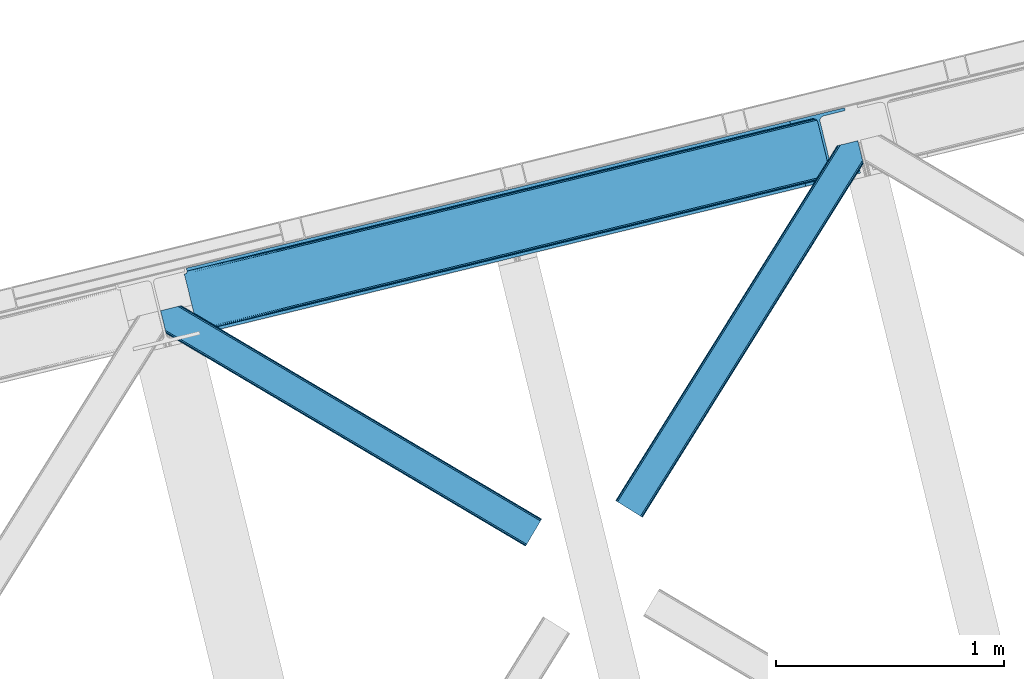
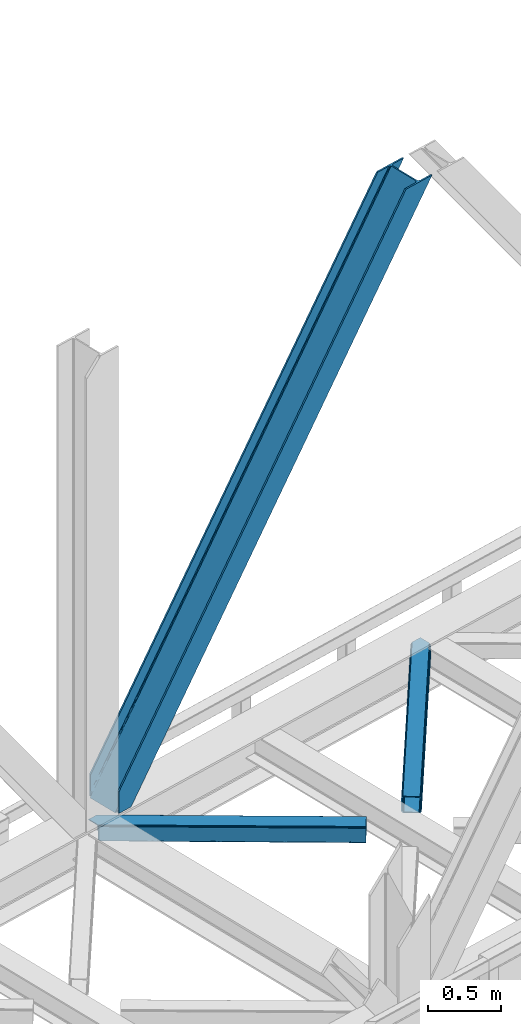
# One storey, part 74 of 93: 3 members.
"""IFC4 building model written with IfcOpenShell, lengths in millimetres."""

from ifc_helpers import new_model, entity, si_unit, converted_unit, derived_unit, direction, frame, origin, place, context, subcontext, project, spatial, triangles, type_object, element, save


model = new_model("IFC4")

# Units and contexts
model_context = context("Model", 3, precision=0.01, world=origin(), true_north=direction((6.12303176911189e-17, 1.0)))
plan_context = context("Plan", 3, precision=0.01, world=origin(), true_north=direction((6.12303176911189e-17, 1.0)))
body_context = subcontext(model_context, "Body", "Model", "MODEL_VIEW")
ifc_project = project(units=[si_unit("LENGTHUNIT", "METRE", prefix="MILLI"), si_unit("AREAUNIT", "SQUARE_METRE"), si_unit("VOLUMEUNIT", "CUBIC_METRE"), converted_unit("PLANEANGLEUNIT", "DEGREE", entity("IfcRatioMeasure", 0.0174532925199433), si_unit("PLANEANGLEUNIT", "RADIAN"), dimensions=[0, 0, 0, 0, 0, 0, 0]), si_unit("MASSUNIT", "GRAM", prefix="KILO"), derived_unit("MASSDENSITYUNIT", [(si_unit("MASSUNIT", "GRAM", prefix="KILO"), 1), (si_unit("LENGTHUNIT", "METRE"), -3)]), derived_unit("MOMENTOFINERTIAUNIT", [(si_unit("LENGTHUNIT", "METRE"), 4)]), si_unit("TIMEUNIT", "SECOND"), si_unit("FREQUENCYUNIT", "HERTZ"), si_unit("THERMODYNAMICTEMPERATUREUNIT", "DEGREE_CELSIUS"), derived_unit("THERMALTRANSMITTANCEUNIT", [(si_unit("MASSUNIT", "GRAM", prefix="KILO"), 1), (si_unit("THERMODYNAMICTEMPERATUREUNIT", "KELVIN"), -1), (si_unit("TIMEUNIT", "SECOND"), -3)]), derived_unit("VOLUMETRICFLOWRATEUNIT", [(si_unit("LENGTHUNIT", "METRE"), 3), (si_unit("TIMEUNIT", "SECOND"), -1)]), derived_unit("MASSFLOWRATEUNIT", [(si_unit("MASSUNIT", "GRAM", prefix="KILO"), 1), (si_unit("TIMEUNIT", "SECOND"), -1)]), derived_unit("ROTATIONALFREQUENCYUNIT", [(si_unit("TIMEUNIT", "SECOND"), -1)]), si_unit("ELECTRICCURRENTUNIT", "AMPERE"), si_unit("ELECTRICVOLTAGEUNIT", "VOLT"), si_unit("POWERUNIT", "WATT"), si_unit("FORCEUNIT", "NEWTON", prefix="KILO"), si_unit("ILLUMINANCEUNIT", "LUX"), si_unit("LUMINOUSFLUXUNIT", "LUMEN"), si_unit("LUMINOUSINTENSITYUNIT", "CANDELA"), derived_unit("USERDEFINED", [(si_unit("MASSUNIT", "GRAM", prefix="KILO"), -1), (si_unit("LENGTHUNIT", "METRE"), -2), (si_unit("TIMEUNIT", "SECOND"), 3), (si_unit("LUMINOUSFLUXUNIT", "LUMEN"), 1)]), derived_unit("LINEARVELOCITYUNIT", [(si_unit("LENGTHUNIT", "METRE"), 1), (si_unit("TIMEUNIT", "SECOND"), -1)]), si_unit("PRESSUREUNIT", "PASCAL"), derived_unit("USERDEFINED", [(si_unit("LENGTHUNIT", "METRE"), -2), (si_unit("MASSUNIT", "GRAM", prefix="KILO"), 1), (si_unit("TIMEUNIT", "SECOND"), -2)]), derived_unit("LINEARFORCEUNIT", [(si_unit("MASSUNIT", "GRAM", prefix="KILO"), 1), (si_unit("LENGTHUNIT", "METRE"), 1), (si_unit("TIMEUNIT", "SECOND"), -2), (si_unit("LENGTHUNIT", "METRE"), -1)]), derived_unit("PLANARFORCEUNIT", [(si_unit("MASSUNIT", "GRAM", prefix="KILO"), 1), (si_unit("LENGTHUNIT", "METRE"), 1), (si_unit("TIMEUNIT", "SECOND"), -2), (si_unit("LENGTHUNIT", "METRE"), -2)])], contexts=[model_context, plan_context])

# Site, building, storey
site_placement = place(None, origin())
site = spatial("IfcSite", under=ifc_project, at=site_placement, CompositionType="ELEMENT")
building_placement = place(site_placement, origin())
building = spatial("IfcBuilding", under=site, at=building_placement, CompositionType="ELEMENT")
storey_placement = place(building_placement, frame((0.0, 0.0, 15900.0)))
storey = spatial("IfcBuildingStorey", under=building, at=storey_placement, CompositionType="ELEMENT", Elevation=15900.0)

# Members
member_type_1 = type_object("IfcMemberType", PredefinedType="BRACE")
member_1_placement = place(storey_placement, frame((-17772.4500732422, 16327.861505127, 3694.99929199219)))
element("IfcMember", 1, at=member_1_placement, inside=storey, type_object=member_type_1, ObjectType="Steel Vertical Brace", PredefinedType="BRACE", context=body_context, shape_type="Tessellation", body=[
    triangles([(58.5487518310547, 26.6239562988285, 0.0), (60.4428222656243, 18.8523376464855, 0.0), (59.1045318603501, 19.6697296142574, 0.80925292968459), (58.9696563720681, 18.4930572509766, 1.10690917968532), (64.089111328125, 19.7406555175785, 8.31577148437282), (64.089111328125, 19.7406555175785, 0.0), (522.90412902832, 126.715521240234, 658.855133056641), (68.377221679686, 19.9243652343757, 14.8293273925774), (72.4072082519524, 18.4523620605469, 22.4381652832017), (524.58542175293, 133.136059570314, 656.552947998047), (73.9838562011719, 17.2861541748043, 26.4425720214822), (2834.75371398926, 696.263314819336, 3911.00081176758), (2834.77231750488, 703.358230590822, 3911.00081176758), (2385.95203857422, 593.953280639647, 3278.7231262207), (2386.50781860352, 586.99905395508, 3279.53005371094), (2831.44228820801, 689.446289062502, 3911.00081176758), (2384.82652587891, 580.578515625, 3281.83223876953), (2825.34033508301, 683.941973876952, 3911.00081176758), (2381.17326049805, 575.671838378907, 3285.27854003906), (2817.37686767578, 680.591015625001, 3911.00081176758), (2376.0933380127, 573.023162841799, 3289.34108276367), (514.170941162109, 119.160168457032, 666.36397705078), (519.250863647459, 121.80884399414, 662.301434326171), (77.0987823486321, 12.6189971923832, 50.6410949707024), (76.5662567138679, 13.8991516113292, 38.6743835449197), (75.4046997070291, 15.4258026123043, 33.1630920410134), (524.029641723631, 140.090286254885, 655.74602050781), (990.06514892578, 246.601226806642, 1312.29896850586), (989.509368896484, 253.55545349121, 1311.48971557617), (1455.54603881836, 360.067556762695, 1968.04266357422), (1454.99025878906, 367.021783447266, 1967.23341064453), (1921.02692871094, 473.532723999024, 2623.78635864258), (1920.47114868164, 480.486950683595, 2622.97710571289), (988.385018920897, 240.180688476563, 1314.598828125), (1453.86590881348, 353.647018432619, 1970.34484863281), (1919.34563598633, 467.113348388672, 2626.08854370117), (984.73175354004, 235.274011230469, 1318.04512939453), (1450.21264343262, 348.740341186525, 1973.78882446289), (1915.69237060547, 462.20550842285, 2629.53251953125), (979.651831054685, 232.626498413085, 1322.10767211914), (1445.13272094727, 346.091665649414, 1977.85369262695), (1910.61361083984, 459.55799560547, 2633.59738769531), (77.0987823486321, 12.6189971923832, 182.433050537107), (2723.82443847656, 657.786593627929, 3911.00081176758), (75.5709686279297, 15.550213623048, 0.0), (77.3813232421853, 11.6585906982418, 0.0), (77.3813232421853, 11.6585906982418, 182.495837402341), (68.377221679686, 19.9243652343757, 0.0), (72.4072082519524, 18.4523620605469, 0.0), (2726.9033203125, 645.155969238282, 3911.00081176758), (80.223010253907, 0.0, 182.495837402341), (80.223010253907, 0.0, 0.0), (191.325531005859, 27.0820678710934, 0.0), (2967.55374755859, 703.817504882814, 3911.00081176758), (1399.80990600586, 593.392849731446, 1967.23341064453), (2779.59196472168, 929.729296874999, 3911.00081176758), (2330.77052307129, 820.324346923828, 3278.7231262207), (1865.29079589844, 706.859179687499, 2622.97710571289), (934.329016113279, 479.927682495118, 1311.48971557617), (468.848126220702, 366.461352539061, 655.74602050781), (3.36839904784938, 252.996185302736, 0.0), (2964.47486572266, 716.448129272461, 3911.00081176758), (188.24664916992, 39.7126922607422, 0.0), (2870.92243652344, 693.643707275392, 3911.00081176758), (94.6942199707009, 16.9082702636715, 0.0), (2862.31133422851, 692.954214477539, 3911.00081176758), (86.083117675782, 16.2187774658214, 0.0), (2854.36065673828, 695.031994628907, 3911.00081176758), (78.1324401855454, 18.2977203369137, 0.0), (2848.28312072754, 699.561950683596, 3911.00081176758), (72.0549041748054, 22.8265136718746, 0.0), (2845.00192565918, 705.851101684571, 3911.00081176758), (68.7737091064446, 29.1168273925778, 0.0), (2789.82157287598, 932.223330688475, 3911.00081176758), (13.5933563232429, 255.487893676758, 0.0), (2789.83901367187, 939.318246459961, 3911.00081176758), (13.611959838865, 262.582809448244, 0.0), (2793.15160217285, 946.135272216796, 3911.00081176758), (16.9233856201172, 269.400997924806, 0.0), (2799.25355529785, 951.639587402346, 3911.00081176758), (23.0253387451157, 274.904150390625, 0.0), (2807.21585998535, 954.990545654297, 3911.00081176758), (30.9876434326179, 278.255108642579, 0.0), (2900.76828918457, 977.794967651369, 3911.00081176758), (124.54123535156, 301.059530639648, 0.0), (2897.69057006836, 990.425592041016, 3911.00081176758), (121.462353515624, 313.690155029299, 0.0), (2770.23323364258, 940.54956665039, 3911.00081176758), (2762.28255615234, 942.627346801759, 3911.00081176758), (2657.04014282226, 931.764056396483, 3911.00081176758), (2753.67145385742, 941.937854003905, 3911.00081176758), (2660.1190246582, 919.133432006836, 3911.00081176758), (2776.31076965332, 936.019610595702, 3911.00081176758), (10.3598327636719, 286.608087158203, 182.495837402341), (10.3598327636719, 286.608087158203, 0.0), (13.2015197753899, 274.94949645996, 182.495837402341), (13.3933685302727, 273.966998291015, 182.433050537107), (1381.42614440918, 607.439666748049, 1977.85369262695), (1846.90703430176, 720.904833984374, 2633.59738769531), (2312.38792419434, 834.37116394043, 3289.34108276367), (915.945254516602, 493.973336791993, 1322.10767211914), (13.3933685302727, 273.966998291015, 50.6410949707024), (450.465527343749, 380.507006835936, 666.36397705078), (13.2015197753899, 274.94949645996, 0.0), (13.509640502929, 272.584524536132, 38.6743835449197), (13.3852294921853, 270.661386108399, 0.0), (13.3852294921853, 270.661386108399, 32.1678039550752), (12.4759826660156, 268.182467651366, 26.1867736816384), (11.9120635986328, 266.629074096682, 22.4381652832017), (11.9120635986328, 266.629074096682, 0.0), (9.01107788085938, 263.467639160155, 14.8293273925774), (9.01107788085938, 263.467639160155, 0.0), (5.11945495605323, 261.6572845459, 8.31577148437282), (5.11945495605323, 261.6572845459, 0.0), (1.4731658935525, 260.767803955079, 0.0), (461.695074462888, 377.818798828126, 658.855133056641), (456.194247436524, 380.49305419922, 662.301434326171), (466.141314697266, 372.892355346679, 656.552947998047), (0.661587524413335, 259.426025390627, 0.80925292968459), (0.0, 260.409686279296, 1.10690917968532), (2318.11664428711, 834.35721130371, 3285.27854003906), (2323.61747131348, 831.681793212892, 3281.83223876953), (2328.06371154785, 826.755349731446, 3279.53005371094), (921.673974609374, 493.959384155272, 1318.04512939453), (1387.15486450195, 607.425714111328, 1973.78882446289), (1852.63575439453, 720.890881347657, 2629.53251953125), (927.175964355469, 491.283966064455, 1314.598828125), (1392.65685424805, 604.750296020507, 1970.34484863281), (1858.1365814209, 718.215463256836, 2626.08854370117), (931.622204589843, 486.357522583008, 1312.29896850586), (1397.10309448242, 599.823852539064, 1968.04266357422), (1862.583984375, 713.28901977539, 2623.78635864258)], [[1, 2, 3], [4, 3, 2], [5, 4, 6], [2, 6, 4], [7, 8, 9], [10, 3, 8], [8, 7, 10], [9, 11, 7], [3, 4, 5], [5, 8, 3], [12, 13, 14], [14, 15, 12], [16, 12, 15], [15, 17, 16], [18, 16, 17], [17, 19, 18], [20, 18, 19], [19, 21, 20], [22, 23, 24], [25, 24, 23], [25, 7, 26], [25, 23, 7], [11, 26, 7], [10, 27, 1], [1, 3, 10], [28, 29, 10], [27, 10, 29], [30, 31, 28], [29, 28, 31], [32, 33, 31], [31, 30, 32], [15, 14, 33], [33, 32, 15], [34, 28, 10], [10, 7, 34], [35, 30, 28], [28, 34, 35], [36, 32, 35], [30, 35, 32], [17, 15, 32], [32, 36, 17], [37, 34, 7], [7, 23, 37], [38, 35, 34], [34, 37, 38], [39, 36, 35], [35, 38, 39], [19, 17, 39], [36, 39, 17], [40, 37, 22], [23, 22, 37], [41, 38, 40], [37, 40, 38], [42, 39, 41], [38, 41, 39], [21, 19, 39], [39, 42, 21], [41, 43, 44], [44, 21, 42], [21, 44, 20], [42, 41, 44], [43, 41, 40], [40, 22, 43], [24, 43, 22], [45, 11, 9], [45, 26, 11], [46, 25, 26], [46, 47, 24], [43, 24, 47], [24, 25, 46], [26, 45, 46], [48, 8, 5], [5, 6, 48], [49, 9, 8], [8, 48, 49], [9, 49, 45], [47, 44, 43], [50, 47, 51], [47, 50, 44], [52, 51, 46], [47, 46, 51], [50, 53, 54], [53, 50, 51], [52, 53, 51], [33, 55, 31], [13, 56, 57], [58, 14, 57], [55, 33, 58], [57, 14, 13], [58, 33, 14], [31, 59, 29], [59, 60, 27], [59, 31, 55], [61, 1, 60], [59, 27, 29], [60, 1, 27], [62, 54, 53], [53, 63, 62], [64, 62, 63], [63, 65, 64], [66, 64, 65], [65, 67, 66], [68, 66, 67], [67, 69, 68], [70, 68, 69], [69, 71, 70], [72, 70, 71], [71, 73, 72], [74, 72, 75], [73, 75, 72], [76, 74, 77], [75, 77, 74], [78, 76, 79], [77, 79, 76], [80, 78, 81], [79, 81, 78], [82, 80, 83], [81, 83, 80], [84, 82, 85], [83, 85, 82], [86, 84, 85], [85, 87, 86], [56, 13, 72], [16, 18, 66], [20, 50, 54], [44, 50, 20], [18, 20, 64], [13, 12, 70], [12, 16, 68], [88, 80, 89], [90, 91, 86], [91, 89, 82], [90, 92, 91], [88, 93, 78], [93, 56, 76], [74, 56, 72], [64, 66, 18], [70, 12, 68], [66, 68, 16], [70, 72, 13], [54, 64, 20], [54, 62, 64], [82, 89, 80], [78, 93, 76], [74, 76, 56], [78, 80, 88], [82, 86, 91], [86, 82, 84], [90, 87, 94], [90, 86, 87], [87, 95, 94], [96, 90, 94], [92, 96, 97], [96, 92, 90], [92, 97, 98], [98, 99, 92], [99, 100, 92], [91, 92, 100], [101, 98, 97], [97, 102, 103], [103, 101, 97], [104, 96, 94], [94, 95, 104], [104, 105, 102], [104, 106, 107], [107, 105, 104], [96, 104, 102], [102, 97, 96], [108, 106, 109], [108, 107, 106], [110, 109, 106], [109, 110, 111], [112, 111, 110], [111, 112, 113], [114, 113, 112], [75, 73, 61], [114, 75, 61], [114, 112, 75], [114, 61, 115], [79, 77, 110], [77, 75, 112], [106, 79, 110], [110, 77, 112], [73, 1, 61], [6, 73, 48], [1, 6, 2], [1, 73, 6], [48, 71, 49], [49, 71, 69], [73, 71, 48], [45, 49, 69], [104, 81, 79], [79, 106, 104], [95, 81, 104], [83, 95, 87], [87, 85, 83], [83, 81, 95], [45, 69, 46], [52, 67, 65], [46, 69, 67], [52, 46, 67], [65, 53, 52], [53, 65, 63], [116, 117, 105], [105, 107, 116], [118, 111, 113], [113, 119, 118], [118, 116, 108], [108, 109, 118], [109, 111, 118], [113, 120, 119], [107, 108, 116], [117, 103, 102], [102, 105, 117], [89, 91, 121], [100, 121, 91], [88, 89, 122], [121, 122, 89], [93, 88, 123], [122, 123, 88], [56, 93, 57], [123, 57, 93], [124, 101, 103], [103, 117, 124], [125, 98, 101], [101, 124, 125], [126, 99, 98], [98, 125, 126], [121, 100, 126], [99, 126, 100], [127, 124, 116], [117, 116, 124], [128, 125, 127], [124, 127, 125], [129, 126, 128], [125, 128, 126], [122, 121, 126], [126, 129, 122], [130, 127, 118], [116, 118, 127], [131, 128, 130], [127, 130, 128], [132, 129, 128], [128, 131, 132], [123, 122, 132], [129, 132, 122], [60, 118, 61], [119, 61, 118], [59, 130, 118], [118, 60, 59], [55, 131, 130], [130, 59, 55], [58, 132, 55], [131, 55, 132], [57, 123, 58], [132, 58, 123], [120, 113, 114], [114, 115, 120], [115, 61, 119], [119, 120, 115]]),
])
member_type_2 = type_object("IfcMemberType", PredefinedType="BRACE")
member_2_placement = place(storey_placement, frame((-15879.7435089111, 15520.9677337647, 3510.00011901855)))
element("IfcMember", 2, at=member_2_placement, inside=storey, type_object=member_type_2, ObjectType="Steel Horizontal Brace", PredefinedType="BRACE", context=body_context, shape_type="Tessellation", body=[
    triangles([(933.020956420898, 1535.69230957031, 0.0), (967.780462646484, 1393.09287414551, 0.0), (14.8444427490231, 64.8704589843746, 0.0), (103.914587402343, 9.2680389404286, 0.0), (928.803771972656, 1552.99241638184, 5.49966430664063), (928.943298339844, 1552.41687011719, 5.20782165527635), (930.803649902344, 1544.78826599121, 1.33247680664135), (971.997647094726, 1375.79393005371, 5.49966430664063), (971.856958007813, 1376.36831359863, 5.20782165527635), (969.997769165038, 1383.99808044434, 1.33247680664135), (972.208099365234, 1375.53813171387, 5.85313110351854), (972.423202514648, 1375.28349609375, 6.20659790039281), (928.911904907227, 1553.57028808594, 5.74383544921875), (972.725509643555, 1375.53929443359, 6.35310058594041), (929.027014160156, 1554.1772277832, 5.9996337890625), (973.026654052734, 1375.79393005371, 6.49960327148438), (929.142123413085, 1554.78416748047, 6.25659484863354), (929.254907226563, 1555.3632019043, 6.49960327148438), (4.34857177734375, 71.4235473632798, 5.12526855468968), (1.13016357421839, 73.4315643310547, 10.8028289794929), (973.360354614257, 1630.84347839356, 10.8028289794929), (976.915951538085, 1631.71086730957, 6.49960327148438), (9.16455688476526, 68.4167541503903, 1.33247680664135), (971.508142089844, 1630.39234313965, 17.5000946044929), (0.0, 74.1373352050778, 17.5000946044929), (1081.10145263672, 1548.91824645996, 6.49960327148438), (1056.20878601074, 1651.03875732422, 6.49960327148438), (971.508142089844, 1630.39234313965, 122.500662231447), (0.0, 74.1373352050778, 122.500662231447), (973.360354614257, 1630.84347839356, 129.197927856447), (1.13016357421839, 73.4315643310547, 129.197927856447), (978.633288574218, 1632.12944641113, 134.874325561526), (4.34857177734375, 71.4235473632798, 134.874325561526), (986.526992797852, 1634.05374755859, 138.667117309571), (9.16455688476526, 68.4167541503903, 138.667117309571), (995.840377807617, 1636.32337646484, 139.999594116212), (14.8444427490231, 64.8704589843746, 139.999594116212), (118.757867431641, 0.0, 17.5000946044929), (117.628866577148, 0.705770874023074, 10.8028289794929), (1085.14190368652, 1551.25182495117, 10.9783996582046), (1087.41734619141, 1552.56569824219, 13.5003387451179), (109.594473266601, 5.72174377441297, 1.33247680664135), (114.410458374023, 2.71495056152344, 5.12526855468968), (1087.56966247559, 1551.93550415039, 17.5000946044929), (1081.77699279785, 1575.70265808105, 139.999594116212), (1063.00837097168, 1652.6967956543, 139.999594116212), (103.914587402343, 9.2680389404286, 139.999594116212), (1083.99429931641, 1566.60786437988, 138.667117309571), (109.594473266601, 5.72174377441297, 138.667117309571), (1085.87325439453, 1558.89670715332, 134.874325561526), (114.410458374023, 2.71495056152344, 134.874325561526), (1087.12899169922, 1553.74469604492, 129.197927856447), (117.628866577148, 0.705770874023074, 129.197927856447), (1087.56966247559, 1551.93550415039, 122.500662231447), (118.757867431641, 0.0, 122.500662231447), (1082.5362487793, 1566.77413330078, 12.1260040283232), (1083.96523132324, 1566.72529907227, 13.5003387451179), (1077.85165100098, 1569.98672790527, 8.3320495605476), (1074.64603271484, 1577.50138549805, 6.99957275390625), (1056.69131469727, 1651.1561920166, 6.99957275390625), (1005.57350463867, 1638.69648742676, 6.99957275390625), (20.7836151123047, 61.163708496093, 6.99957275390625), (97.9789031982418, 12.9759521484375, 6.99957275390625), (108.475936889648, 6.42286376953052, 12.1260040283232), (111.694345092774, 4.41368408203016, 17.8035644531265), (1084.81169128418, 1563.25225524902, 17.8035644531265), (103.659951782227, 9.42849426269458, 8.3320495605476), (1085.25236206055, 1561.44306335449, 24.4996673583992), (112.823345947265, 3.70791320800708, 24.4996673583992), (983.093481445312, 1633.21658935547, 17.8035644531265), (981.241268920898, 1632.76429138183, 24.4996673583992), (7.0693359375, 69.7248138427731, 17.8035644531265), (5.94033508300708, 70.4305847167961, 24.4996673583992), (988.366415405273, 1634.50139465332, 12.1260040283232), (10.2877441406254, 67.716796875, 12.1260040283232), (996.260119628905, 1636.42569580078, 8.3320495605476), (15.1037292480469, 64.7100036621086, 8.3320495605476), (981.241268920898, 1632.76429138183, 115.501089477541), (5.94033508300708, 70.4305847167961, 115.501089477541), (996.260119628905, 1636.42569580078, 131.667544555665), (1005.57350463867, 1638.69648742676, 133.000021362306), (1063.00837097168, 1652.6967956543, 133.000021362306), (988.366415405273, 1634.50139465332, 127.87475280762), (983.093481445312, 1633.21658935547, 122.196029663086), (20.7836151123047, 61.163708496093, 133.000021362306), (15.1037292480469, 64.7100036621086, 131.667544555665), (10.2877441406254, 67.716796875, 127.87475280762), (7.0693359375, 69.7248138427731, 122.196029663086), (108.475936889648, 6.42286376953052, 127.87475280762), (111.694345092774, 4.41368408203016, 122.196029663086), (112.823345947265, 3.70791320800708, 115.501089477541), (97.9789031982418, 12.9759521484375, 133.000021362306), (103.659951782227, 9.42849426269458, 131.667544555665), (1085.25236206055, 1561.44306335449, 115.501089477541), (1084.81169128418, 1563.25225524902, 122.196029663086), (1083.55595397949, 1568.40426635742, 127.87475280762), (1081.67699890137, 1576.11426086426, 131.667544555665), (1079.45969238281, 1585.20905456543, 133.000021362306)], [[1, 2, 3], [4, 3, 2], [1, 5, 2], [6, 5, 1], [1, 7, 6], [2, 5, 8], [8, 9, 2], [10, 2, 9], [11, 8, 5], [12, 11, 13], [14, 12, 15], [16, 14, 17], [17, 18, 16], [15, 17, 14], [13, 15, 12], [5, 13, 11], [17, 19, 18], [19, 17, 15], [13, 19, 15], [19, 13, 5], [5, 6, 19], [20, 21, 18], [18, 19, 20], [21, 22, 18], [19, 6, 7], [7, 1, 23], [3, 23, 1], [7, 23, 19], [24, 21, 20], [20, 25, 24], [18, 26, 16], [26, 18, 22], [27, 26, 22], [28, 24, 29], [25, 29, 24], [30, 28, 31], [29, 31, 28], [32, 30, 33], [31, 33, 30], [34, 32, 35], [33, 35, 32], [36, 34, 37], [35, 37, 34], [38, 39, 40], [40, 41, 38], [42, 10, 9], [39, 12, 16], [16, 40, 39], [16, 26, 40], [9, 39, 43], [9, 12, 39], [9, 43, 42], [2, 10, 4], [42, 4, 10], [41, 44, 38], [45, 36, 37], [36, 45, 46], [37, 47, 45], [48, 45, 47], [47, 49, 48], [50, 48, 49], [49, 51, 50], [52, 50, 51], [51, 53, 52], [54, 52, 53], [53, 55, 54], [44, 54, 38], [55, 38, 54], [56, 40, 26], [41, 40, 56], [56, 57, 41], [58, 26, 59], [26, 58, 56], [60, 59, 26], [59, 61, 62], [61, 59, 60], [62, 63, 59], [64, 65, 66], [66, 57, 64], [58, 59, 63], [63, 67, 58], [56, 58, 67], [67, 64, 56], [57, 56, 64], [68, 66, 65], [65, 69, 68], [70, 71, 72], [73, 72, 71], [74, 70, 75], [72, 75, 70], [76, 74, 77], [75, 77, 74], [61, 76, 62], [77, 62, 76], [71, 78, 79], [79, 73, 71], [34, 36, 80], [46, 81, 36], [81, 46, 82], [81, 80, 36], [83, 34, 80], [83, 32, 34], [32, 84, 30], [84, 32, 83], [28, 84, 78], [84, 28, 30], [61, 22, 76], [70, 74, 22], [74, 76, 22], [61, 60, 22], [71, 70, 24], [21, 24, 70], [28, 71, 24], [71, 28, 78], [70, 22, 21], [80, 81, 85], [85, 86, 80], [83, 80, 86], [86, 87, 83], [84, 83, 87], [87, 88, 84], [78, 84, 88], [88, 79, 78], [53, 89, 90], [91, 38, 55], [53, 90, 55], [53, 51, 89], [90, 91, 55], [89, 51, 49], [92, 47, 37], [47, 93, 49], [93, 47, 92], [93, 89, 49], [39, 64, 43], [69, 38, 91], [38, 65, 39], [65, 38, 69], [39, 65, 64], [4, 63, 3], [42, 43, 64], [64, 67, 42], [67, 63, 4], [4, 42, 67], [87, 35, 33], [37, 85, 92], [37, 86, 85], [86, 37, 35], [87, 86, 35], [79, 29, 25], [31, 88, 87], [33, 31, 87], [88, 31, 29], [79, 88, 29], [23, 75, 19], [3, 63, 62], [62, 77, 3], [77, 75, 23], [23, 3, 77], [20, 19, 75], [25, 73, 79], [72, 25, 20], [25, 72, 73], [72, 20, 75], [66, 41, 57], [54, 44, 68], [44, 66, 68], [68, 94, 54], [44, 41, 66], [95, 54, 94], [52, 54, 95], [50, 95, 96], [95, 50, 52], [96, 48, 50], [97, 48, 96], [97, 98, 45], [97, 45, 48], [98, 46, 45], [98, 82, 46], [81, 98, 85], [81, 82, 98], [92, 85, 98], [95, 94, 90], [91, 90, 94], [96, 95, 89], [90, 89, 95], [97, 96, 93], [89, 93, 96], [98, 97, 92], [93, 92, 97], [94, 68, 69], [69, 91, 94]]),
])
member_type_3 = type_object("IfcMemberType", PredefinedType="BRACE")
member_3_placement = place(storey_placement, frame((-17875.1786865234, 15394.1487304688, 3510.00011901855)))
element("IfcMember", 3, at=member_3_placement, inside=storey, type_object=member_type_3, ObjectType="Steel Horizontal Brace", PredefinedType="BRACE", context=body_context, shape_type="Tessellation", body=[
    triangles([(1672.2107208252, 120.470553588868, 122.500662231447), (1672.2107208252, 120.470553588868, 17.5000946044929), (91.5002288818359, 1056.29133911133, 17.5000946044929), (91.5002288818359, 1056.29133911133, 122.500662231447), (1663.29614868164, 105.412170410156, 139.999594116212), (1666.70756835938, 111.174609375001, 138.667117309571), (76.4767272949211, 1052.62877197266, 138.667117309571), (67.1679931640647, 1050.36030578613, 139.999594116212), (1669.59925231934, 116.060357666016, 134.874325561526), (84.3704315185569, 1054.55307312012, 134.874325561526), (1671.53285522461, 119.325274658204, 129.197927856447), (89.6480163574233, 1055.84020385742, 129.197927856447), (18.767459106446, 956.993911743164, 139.999594116212), (1609.80406494141, 15.0595458984371, 139.999594116212), (0.0, 1033.98688659668, 139.999594116212), (1600.89065551758, 0.0, 122.500662231447), (1601.56852111816, 1.14644165039135, 129.197927856447), (24.5612915039055, 933.226757812499, 122.500662231447), (24.1194580078118, 935.035949707031, 129.197927856447), (1603.50096130371, 4.4113586425774, 134.874325561526), (22.8637207031243, 940.18796081543, 134.874325561526), (1606.3938079834, 9.29594421386719, 138.667117309571), (20.9847656250022, 947.897955322265, 138.667117309571), (1600.89065551758, 0.0, 17.5000946044929), (24.5612915039055, 933.226757812499, 17.5000946044929), (1671.53285522461, 119.325274658204, 10.8028289794929), (89.5573242187493, 1055.81811218262, 10.8167816162131), (162.736578369142, 1012.4207611084, 10.5005218505867), (1669.59925231934, 116.060357666016, 5.12526855468968), (165.152709960938, 1006.73157348633, 5.12526855468968), (164.09696044922, 1011.0638671875, 9.50058288574292), (163.767910766601, 1011.39175415039, 9.74126586914281), (163.414443969727, 1011.74173278809, 10.0005523681648), (163.060977172852, 1012.09287414551, 10.2586761474631), (89.4666320800789, 1055.79602050781, 10.5005218505867), (1666.70756835938, 111.174609375001, 1.33247680664135), (167.031665039063, 999.021578979493, 1.33247680664135), (1663.29614868164, 105.412170410156, 0.0), (169.248971557619, 989.925622558592, 0.0), (1609.80406494141, 15.0595458984371, 0.0), (204.009640502929, 847.326187133789, 0.0), (166.88748779297, 995.391567993163, 10.5005218505867), (72.0339752197287, 1051.54627990723, 10.5005218505867), (168.582733154297, 992.661502075196, 9.50058288574292), (168.164154052734, 993.333554077148, 9.74591674804833), (167.732785034179, 994.025372314452, 10.0005523681648), (167.304904174805, 994.718353271484, 10.2540252685576), (1666.03667907715, 110.037469482422, 12.1260040283232), (1667.96446838379, 113.301223754883, 17.8035644531265), (79.9148895263679, 1053.46709289551, 17.8035644531265), (1663.14383239746, 105.151721191407, 8.3320495605476), (169.397799682618, 989.317520141602, 8.81690368652562), (74.112918090821, 1052.05322570801, 12.4271484375022), (171.566271972657, 980.419226074218, 6.99957275390625), (1659.72776184082, 99.3881195068352, 6.99957275390625), (1668.64698486328, 114.447665405274, 24.4996673583992), (81.7671020507805, 1053.91939086914, 24.4996673583992), (1668.64698486328, 114.447665405274, 115.501089477541), (81.7671020507805, 1053.91939086914, 115.501089477541), (74.6373046875015, 1052.18112487793, 127.87475280762), (66.7436004638694, 1050.25682373047, 131.667544555665), (79.9148895263679, 1053.46709289551, 122.196029663086), (57.4348663330093, 1047.98835754395, 133.000021362306), (0.0, 1033.98688659668, 133.000021362306), (1667.96446838379, 113.301223754883, 122.196029663086), (1666.03667907715, 110.037469482422, 127.87475280762), (1663.14383239746, 105.151721191407, 131.667544555665), (1659.72776184082, 99.3881195068352, 133.000021362306), (16.4501586914084, 966.50030822754, 133.000021362306), (1613.37245178223, 21.0824340820309, 133.000021362306), (1613.37245178223, 21.0824340820309, 6.99957275390625), (201.692340087891, 856.832583618165, 6.99957275390625), (1607.06818542481, 10.4342468261711, 127.87475280762), (1609.96103210449, 15.3199951171882, 131.667544555665), (1604.45787963867, 6.02405090332104, 115.501089477541), (1605.13574523926, 7.17049255371057, 122.196029663086), (1606.3938079834, 9.29594421386719, 1.33247680664135), (1607.06818542481, 10.4342468261711, 12.1260040283232), (1603.50096130371, 4.4113586425774, 5.12526855468968), (1609.96103210449, 15.3199951171882, 8.3320495605476), (1601.56852111816, 1.14644165039135, 10.8028289794929), (1604.45787963867, 6.02405090332104, 24.4996673583992), (1605.13574523926, 7.17049255371057, 17.8035644531265), (18.6674652099609, 957.405514526366, 131.667544555665), (20.5464202880867, 949.694357299804, 127.87475280762), (21.8021575927742, 944.542346191407, 122.196029663086), (22.2439910888679, 942.733154296875, 115.501089477541), (22.2439910888679, 942.733154296875, 24.4996673583992), (21.7812286376975, 944.628387451172, 17.8163543701194), (21.7602996826172, 944.717916870117, 17.5000946044929), (203.86081237793, 847.934289550782, 8.81690368652562), (206.225784301758, 838.23023071289, 1.33247680664135), (204.675878906251, 844.591470336914, 9.50058288574292), (208.105902099611, 830.520236206055, 5.12526855468968), (209.161651611328, 826.187942504883, 9.50058288574292), (204.682855224612, 843.327593994141, 10.2075164794951), (204.323574829101, 843.305502319336, 10.3540191650391), (203.965457153321, 843.284573364257, 10.5005218505867), (27.0088165283196, 945.866683959961, 12.1260040283232), (28.3459442138665, 947.254971313476, 10.5005218505867), (204.677041625979, 843.958950805663, 9.85404968261719), (32.132922363282, 930.36181640625, 10.8179443359404), (209.130258178713, 825.982141113282, 9.88311767578125), (208.116366577149, 826.255380249024, 10.5005218505867), (208.802371215821, 826.071670532227, 10.0842681884787), (32.4968536376946, 930.225778198243, 10.5005218505867)], [[1, 2, 3], [3, 4, 1], [5, 6, 7], [7, 8, 5], [6, 9, 10], [10, 7, 6], [9, 11, 12], [12, 10, 9], [11, 1, 4], [4, 12, 11], [5, 13, 14], [13, 5, 8], [15, 13, 8], [16, 17, 18], [19, 18, 17], [17, 20, 19], [21, 19, 20], [20, 22, 21], [23, 21, 22], [22, 14, 23], [13, 23, 14], [24, 16, 18], [18, 25, 24], [26, 27, 3], [27, 26, 28], [26, 29, 30], [30, 31, 26], [26, 32, 33], [32, 26, 31], [26, 34, 28], [34, 26, 33], [28, 35, 27], [29, 36, 37], [37, 30, 29], [36, 38, 39], [39, 37, 36], [3, 2, 26], [38, 40, 41], [41, 39, 38], [28, 42, 35], [43, 35, 42], [31, 44, 45], [45, 32, 31], [32, 45, 46], [46, 33, 32], [33, 46, 47], [47, 34, 33], [34, 47, 42], [42, 28, 34], [48, 49, 50], [45, 51, 46], [45, 44, 51], [42, 47, 51], [47, 46, 51], [44, 52, 51], [48, 53, 42], [42, 51, 48], [53, 43, 42], [51, 52, 54], [54, 55, 51], [50, 53, 48], [49, 56, 57], [57, 50, 49], [56, 58, 59], [59, 57, 56], [60, 61, 7], [10, 60, 7], [10, 12, 62], [60, 10, 62], [62, 12, 4], [61, 8, 7], [15, 63, 64], [15, 8, 63], [61, 63, 8], [62, 4, 59], [57, 3, 50], [4, 57, 59], [3, 27, 50], [4, 3, 57], [35, 50, 27], [35, 53, 50], [35, 43, 53], [58, 65, 59], [62, 59, 65], [65, 66, 62], [60, 62, 66], [66, 67, 60], [61, 60, 67], [67, 68, 61], [63, 61, 68], [68, 69, 63], [68, 70, 69], [69, 64, 63], [71, 55, 72], [54, 72, 55], [11, 66, 65], [58, 2, 1], [11, 65, 1], [11, 9, 66], [65, 58, 1], [66, 9, 6], [68, 5, 14], [5, 67, 6], [67, 5, 68], [67, 66, 6], [26, 48, 29], [56, 2, 58], [2, 49, 26], [49, 2, 56], [26, 49, 48], [38, 55, 40], [36, 29, 48], [48, 51, 36], [51, 55, 38], [38, 36, 51], [73, 22, 20], [14, 70, 68], [14, 74, 70], [74, 14, 22], [73, 74, 22], [75, 16, 24], [17, 76, 73], [20, 17, 73], [76, 17, 16], [75, 76, 16], [77, 78, 79], [40, 55, 71], [71, 80, 40], [80, 78, 77], [77, 40, 80], [81, 79, 78], [24, 82, 75], [83, 24, 81], [24, 83, 82], [83, 81, 78], [70, 74, 84], [84, 69, 70], [74, 73, 85], [85, 84, 74], [73, 76, 86], [86, 85, 73], [76, 75, 87], [87, 86, 76], [75, 82, 87], [88, 87, 82], [86, 87, 18], [18, 19, 86], [21, 86, 19], [86, 21, 85], [18, 88, 25], [89, 90, 25], [25, 88, 89], [87, 88, 18], [84, 23, 13], [15, 69, 13], [64, 69, 15], [84, 85, 23], [23, 85, 21], [69, 84, 13], [44, 30, 37], [39, 44, 37], [54, 52, 39], [54, 39, 72], [30, 44, 31], [39, 52, 44], [72, 41, 91], [41, 92, 93], [41, 72, 39], [94, 93, 92], [41, 93, 91], [94, 95, 93], [83, 89, 88], [71, 72, 91], [78, 96, 97], [97, 98, 78], [98, 99, 78], [98, 100, 99], [80, 91, 93], [93, 78, 80], [78, 93, 101], [101, 96, 78], [83, 78, 99], [99, 90, 83], [90, 89, 83], [91, 80, 71], [88, 82, 83], [24, 25, 102], [79, 103, 95], [81, 102, 104], [104, 79, 81], [104, 105, 79], [95, 94, 79], [40, 77, 92], [92, 41, 40], [77, 79, 94], [94, 92, 77], [106, 81, 24], [99, 106, 25], [99, 100, 106], [25, 90, 99], [98, 104, 106], [106, 100, 98]]),
])

save(model, "model.ifc")
